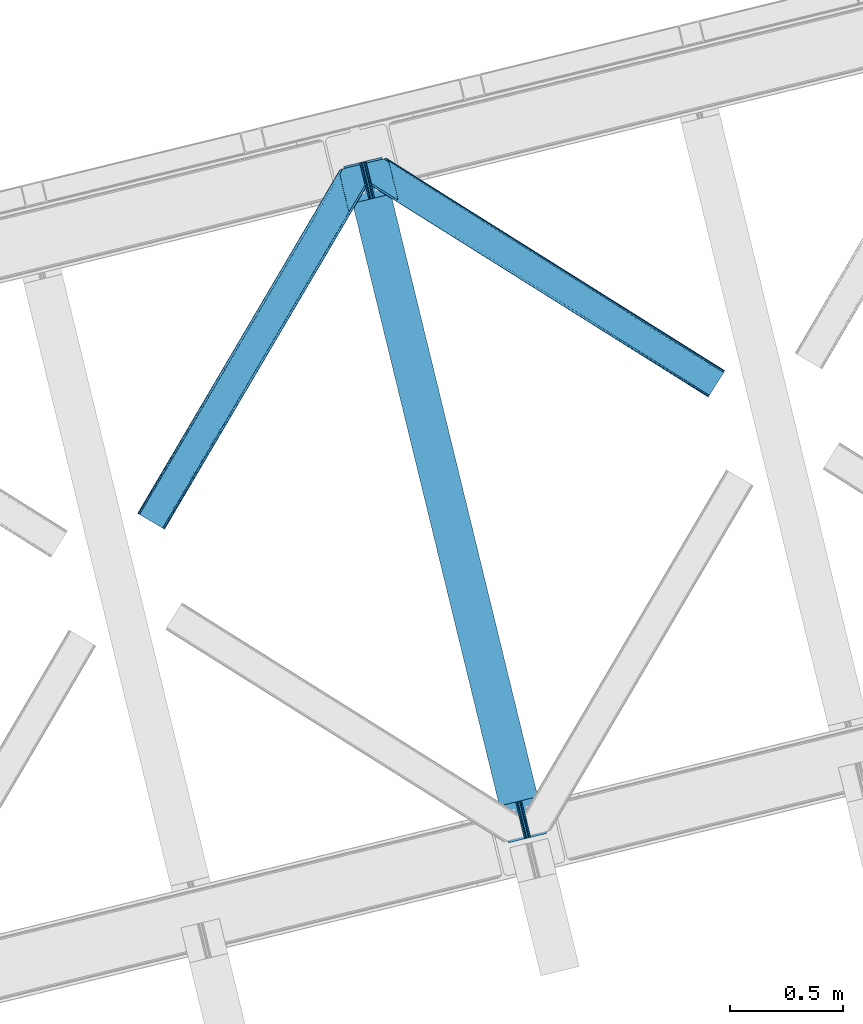
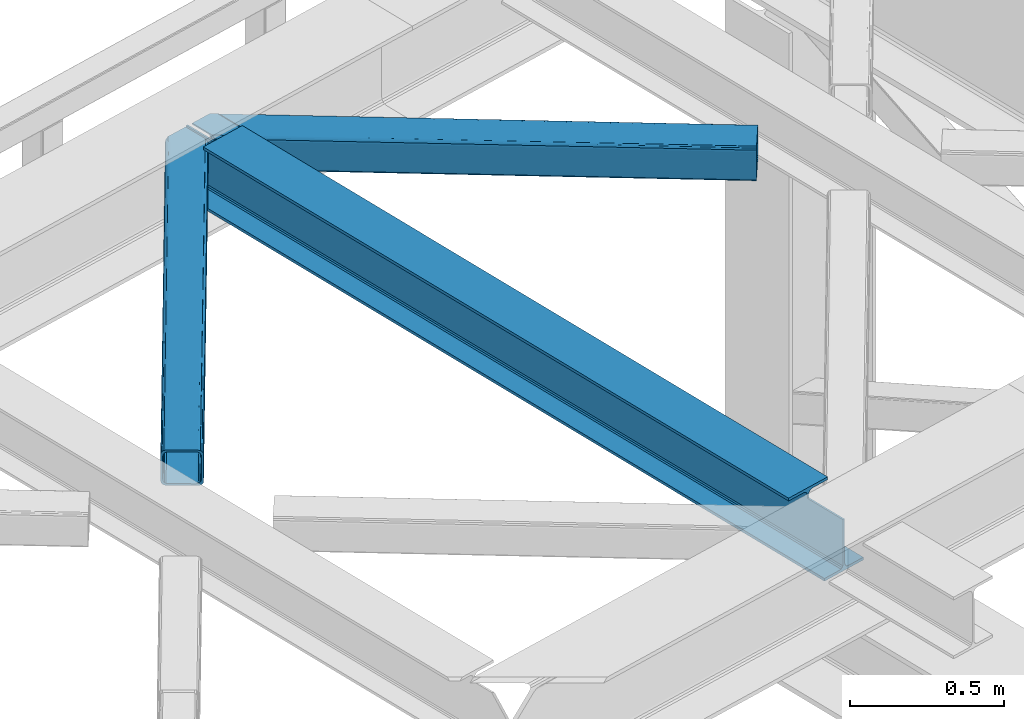
# One storey, part 36 of 92: 2 members, 1 beam.
"""IFC4 building model written with IfcOpenShell, lengths in millimetres."""

from ifc_helpers import new_model, entity, si_unit, converted_unit, derived_unit, direction, frame, origin, place, context, subcontext, project, spatial, triangles, polygons, material, type_object, element, save


model = new_model("IFC4")

# Units and contexts
model_context = context("Model", 3, precision=0.01, world=origin(), true_north=direction((6.12303176911189e-17, 1.0)))
plan_context = context("Plan", 3, precision=0.01, world=origin(), true_north=direction((6.12303176911189e-17, 1.0)))
body_context = subcontext(model_context, "Body", "Model", "MODEL_VIEW")
ifc_project = project(units=[si_unit("LENGTHUNIT", "METRE", prefix="MILLI"), si_unit("AREAUNIT", "SQUARE_METRE"), si_unit("VOLUMEUNIT", "CUBIC_METRE"), converted_unit("PLANEANGLEUNIT", "DEGREE", entity("IfcRatioMeasure", 0.0174532925199433), si_unit("PLANEANGLEUNIT", "RADIAN"), dimensions=[0, 0, 0, 0, 0, 0, 0]), si_unit("MASSUNIT", "GRAM", prefix="KILO"), derived_unit("MASSDENSITYUNIT", [(si_unit("MASSUNIT", "GRAM", prefix="KILO"), 1), (si_unit("LENGTHUNIT", "METRE"), -3)]), derived_unit("MOMENTOFINERTIAUNIT", [(si_unit("LENGTHUNIT", "METRE"), 4)]), si_unit("TIMEUNIT", "SECOND"), si_unit("FREQUENCYUNIT", "HERTZ"), si_unit("THERMODYNAMICTEMPERATUREUNIT", "DEGREE_CELSIUS"), derived_unit("THERMALTRANSMITTANCEUNIT", [(si_unit("MASSUNIT", "GRAM", prefix="KILO"), 1), (si_unit("THERMODYNAMICTEMPERATUREUNIT", "KELVIN"), -1), (si_unit("TIMEUNIT", "SECOND"), -3)]), derived_unit("VOLUMETRICFLOWRATEUNIT", [(si_unit("LENGTHUNIT", "METRE"), 3), (si_unit("TIMEUNIT", "SECOND"), -1)]), derived_unit("MASSFLOWRATEUNIT", [(si_unit("MASSUNIT", "GRAM", prefix="KILO"), 1), (si_unit("TIMEUNIT", "SECOND"), -1)]), derived_unit("ROTATIONALFREQUENCYUNIT", [(si_unit("TIMEUNIT", "SECOND"), -1)]), si_unit("ELECTRICCURRENTUNIT", "AMPERE"), si_unit("ELECTRICVOLTAGEUNIT", "VOLT"), si_unit("POWERUNIT", "WATT"), si_unit("FORCEUNIT", "NEWTON", prefix="KILO"), si_unit("ILLUMINANCEUNIT", "LUX"), si_unit("LUMINOUSFLUXUNIT", "LUMEN"), si_unit("LUMINOUSINTENSITYUNIT", "CANDELA"), derived_unit("USERDEFINED", [(si_unit("MASSUNIT", "GRAM", prefix="KILO"), -1), (si_unit("LENGTHUNIT", "METRE"), -2), (si_unit("TIMEUNIT", "SECOND"), 3), (si_unit("LUMINOUSFLUXUNIT", "LUMEN"), 1)]), derived_unit("LINEARVELOCITYUNIT", [(si_unit("LENGTHUNIT", "METRE"), 1), (si_unit("TIMEUNIT", "SECOND"), -1)]), si_unit("PRESSUREUNIT", "PASCAL"), derived_unit("USERDEFINED", [(si_unit("LENGTHUNIT", "METRE"), -2), (si_unit("MASSUNIT", "GRAM", prefix="KILO"), 1), (si_unit("TIMEUNIT", "SECOND"), -2)]), derived_unit("LINEARFORCEUNIT", [(si_unit("MASSUNIT", "GRAM", prefix="KILO"), 1), (si_unit("LENGTHUNIT", "METRE"), 1), (si_unit("TIMEUNIT", "SECOND"), -2), (si_unit("LENGTHUNIT", "METRE"), -1)]), derived_unit("PLANARFORCEUNIT", [(si_unit("MASSUNIT", "GRAM", prefix="KILO"), 1), (si_unit("LENGTHUNIT", "METRE"), 1), (si_unit("TIMEUNIT", "SECOND"), -2), (si_unit("LENGTHUNIT", "METRE"), -2)])], contexts=[model_context, plan_context])

# Site, building, storey
site_placement = place(None, origin())
site = spatial("IfcSite", under=ifc_project, at=site_placement, CompositionType="ELEMENT")
building_placement = place(site_placement, origin())
building = spatial("IfcBuilding", under=site, at=building_placement, CompositionType="ELEMENT")
storey_placement = place(building_placement, frame((0.0, 0.0, 15900.0)))
storey = spatial("IfcBuildingStorey", under=building, at=storey_placement, Name="05", CompositionType="ELEMENT", Elevation=15900.0)

# Beam
ifc_material = material(Name="Metal painted (White)")
beam_type = type_object("IfcBeamType", PredefinedType="BEAM")
beam_placement = place(storey_placement, frame((-52349.25, 5026.02, 3441.0)))
element("IfcBeam", 1, at=beam_placement, inside=storey, type_object=beam_type, material=ifc_material, ObjectType="Steel Beam", PredefinedType="BEAM", context=body_context, shape_type="Tessellation", body=[
    polygons([(900.98534618944, 41.4445662733081, 11.000000000004), (900.98534618944, 41.4445662733092, 2.16573425859679e-12), (170.021610174761, 3040.13999372697, 2.16573425859679e-12), (170.021610174761, 3040.13999372697, 11.000000000004), (834.919806235814, 25.3403919499656, 11.000000000004), (103.956070221144, 3024.03581940362, 11.000000000004), (828.971056214522, 23.8903211957396, 12.2179274798217), (98.0073201998427, 3022.5857486494, 12.2179274798217), (823.927949458413, 22.6610105689194, 15.6862915010192), (92.964213443734, 3021.35643802258, 15.6862915010192), (820.558253255237, 21.8396114687119, 20.8770650821657), (89.5945172405581, 3020.53503892237, 20.8770650821657), (819.374973305552, 21.5511744621195, 27.0000000000047), (88.4112372908723, 3020.24660191578, 27.0000000000047), (81.6103728838888, 3018.58881926485, 27.0000000000047), (81.6103728838801, 3018.58881926485, 203.000000000006), (88.4112372908723, 3020.24660191578, 203.000000000006), (0.0, 2998.69542745366, 2.16573425859679e-12), (0.0, 2998.69542745366, 10.9999999999997), (66.0655399536259, 3014.799601777, 11.000000000004), (72.0142899749184, 3016.24967253123, 12.2179274798217), (77.0573967310183, 3017.47898315805, 15.6862915010192), (80.4270929342029, 3018.30038225826, 20.8770650821657), (819.374973305552, 21.5511744621195, 203.000000000006), (812.574108898559, 19.8933918111876, 203.000000000006), (812.574108898559, 19.8933918111886, 27.0000000000047), (811.390828948873, 19.6049548045974, 20.8770650821657), (808.021132745698, 18.7835557043887, 15.6862915010192), (802.978025989589, 17.5542450775696, 12.2179274798217), (797.029275968305, 16.1041743233425, 11.000000000004), (730.963736014671, 0.0, 10.9999999999997), (730.963736014671, 0.0, 2.16573425859679e-12), (779.675212882749, 184.415062601691, 203.069791966819), (128.020401343504, 2857.75452019162, 203.000000000006), (128.24328213265, 2856.8401777572, 203.617301946336), (128.256196377169, 2856.7871977843, 217.000003693143), (779.530009633824, 185.010597404071, 217.000003676718), (779.530880241722, 185.007025963191, 204.00000679514), (772.964911718311, 182.385463974442, 203.006342981529), (772.742064056773, 183.299815969774, 203.617301946336), (772.729149812254, 183.352795942667, 217.000003693143), (121.455336555608, 2855.1293963229, 217.000003676718), (121.454465947701, 2855.13296776377, 204.00000679514), (121.310166358655, 2855.72494066435, 203.076120467494), (121.219536936511, 2856.09673754069, 203.000000000006), (780.71349435786, 185.298194377514, 223.122939328039), (784.082490766539, 186.122464201393, 228.313710402595), (789.125126170563, 187.353708426697, 231.782072735464), (795.073705041266, 188.80448128138, 232.999999602236), (861.13915590679, 204.909021065315, 232.999999283132), (861.137682570352, 204.915065042187, 243.999994005812), (691.116301666431, 163.469558245298, 243.999994827032), (691.117775002869, 163.463514268423, 233.000000104353), (757.183225868392, 179.568054052358, 232.999999785253), (763.132130996722, 181.017488520583, 231.782072861012), (768.175695503853, 182.244921343717, 228.313710479427), (771.546082413593, 183.063487001147, 223.12293937232), (120.271851831563, 2854.84179934945, 223.122939328039), (116.902855422884, 2854.01752952557, 228.313710402595), (111.860220018877, 2852.78628530027, 231.782072735464), (105.911641148165, 2851.33551244559, 232.999999602236), (39.8461902826419, 2835.23097266165, 232.999999283128), (39.8476636190794, 2835.22492868478, 243.999994005812), (209.869044523001, 2876.67043548167, 243.999994827032), (209.867571186554, 2876.67647945854, 233.000000104357), (143.802120321031, 2860.57193967461, 232.999999785253), (137.853215192701, 2859.12250520639, 231.782072861012), (132.80965068557, 2857.89507238325, 228.313710479427), (129.439263775838, 2857.07650672582, 223.12293937232)], [[[1, 2, 3, 4]], [[5, 1, 4, 6]], [[7, 5, 6, 8]], [[9, 7, 8, 10]], [[11, 9, 10, 12]], [[13, 11, 12, 14]], [[15, 16, 17, 14, 12, 10, 8, 6, 4, 3, 18, 19, 20, 21, 22, 23]], [[13, 24, 25, 26, 27, 28, 29, 30, 31, 32, 2, 1, 5, 7, 9, 11]], [[2, 32, 18, 3]], [[32, 31, 19, 18]], [[31, 30, 20, 19]], [[27, 26, 15, 23]], [[28, 27, 23, 22]], [[29, 28, 22, 21]], [[30, 29, 21, 20]], [[33, 24, 13, 14, 17, 34, 35, 36, 37, 38]], [[25, 39, 40, 41, 42, 43, 44, 16, 15, 26]], [[39, 25, 24, 33]], [[45, 34, 17, 16]], [[41, 40, 38, 37, 46, 47, 48, 49, 50, 51, 52, 53, 54, 55, 56, 57]], [[42, 58, 59, 60, 61, 62, 63, 64, 65, 66, 67, 68, 69, 36, 35, 43]], [[46, 37, 36, 69]], [[47, 46, 69, 68]], [[48, 47, 68, 67]], [[49, 48, 67, 66]], [[50, 49, 66, 65]], [[51, 50, 65, 64]], [[52, 51, 64, 63]], [[53, 52, 63, 62]], [[54, 53, 62, 61]], [[55, 54, 61, 60]], [[56, 55, 60, 59]], [[57, 56, 59, 58]], [[41, 57, 58, 42]]], closed=False),
])

# Members
member_type_1 = type_object("IfcMemberType", PredefinedType="BRACE")
member_1_placement = place(storey_placement, frame((-52247.53, 7001.53, 3511.0)))
element("IfcMember", 2, at=member_1_placement, inside=storey, type_object=member_type_1, ObjectType="Steel Horizontal Brace", PredefinedType="BRACE", context=body_context, shape_type="Tessellation", body=[
    triangles([(207.717553710936, 841.064360046387, 0.0), (172.040661621089, 987.427519226075, 0.0), (1579.91751708985, 103.755294799805, 0.0), (1524.09766845703, 14.8223510742191, 0.0), (1589.22392578125, 118.577645874024, 17.5000946044929), (1588.51234130859, 117.449226379395, 10.8028289794929), (166.547973632813, 1009.96393432617, 10.8028289794929), (166.092187499999, 1011.82079772949, 17.5000946044929), (1586.49851074219, 114.236050415039, 5.12526855468968), (167.836267089842, 1004.67646636963, 5.12526855468968), (1583.48009033203, 109.42762298584, 1.33247680664135), (169.766381835936, 996.762414550782, 1.33247680664135), (1520.53974609375, 9.15002288818323, 1.33247680664135), (202.587634277341, 836.379180908203, 1.33247680664135), (208.508203124999, 837.822697448731, 0.155804443362285), (1517.52132568359, 4.34159545898456, 5.12526855468968), (194.895080566406, 834.504295349121, 5.12526855468968), (1515.50284423828, 1.12841949462927, 10.8028289794929), (189.755859375, 833.250883483887, 10.8028289794929), (1514.79591064453, 0.0, 17.5000946044929), (187.946667480464, 832.811375427246, 17.5000946044929), (204.378222656247, 836.815782165528, 12.1260040283232), (208.508203124999, 837.822697448731, 9.69243164062573), (199.648278808592, 835.662945556641, 17.9802978515654), (198.420446777345, 835.364126586915, 19.4999725341804), (187.946667480464, 832.811375427246, 19.4999725341804), (25.3054321289019, 934.895260620117, 19.4999725341804), (22.6823364257798, 945.669602966309, 19.4999725341804), (1514.79591064453, 0.0, 122.500662231447), (25.3054321289019, 934.895260620117, 122.500662231447), (1527.81837158203, 20.7510589599606, 6.99957275390625), (205.340954589839, 850.821903991699, 6.99957275390625), (207.559423828126, 841.724784851074, 8.88434143066479), (1524.26044921875, 15.0787307739256, 8.3320495605476), (1521.24202880859, 10.2703033447269, 12.1260040283232), (1519.22354736328, 7.05712738037073, 17.8035644531265), (1518.51661376953, 5.92870788574237, 24.4996673583992), (22.9288330078125, 944.65280456543, 24.4996673583992), (174.417260742186, 977.669975280762, 6.99957275390625), (1576.19681396485, 97.8265869140623, 6.99957275390625), (168.966430664063, 1000.03372650147, 17.8803039550803), (170.212866210939, 994.918922424316, 12.1260040283232), (172.142980957033, 987.004870605469, 8.3320495605476), (168.831555175777, 1000.58485565186, 18.5000335693367), (166.092187499999, 1011.82079772949, 18.5000335693367), (1518.51661376953, 5.92870788574237, 115.501089477541), (22.9288330078125, 944.65280456543, 115.501089477541), (1527.81837158203, 20.7510589599606, 133.000021362306), (1524.26044921875, 15.0787307739256, 131.667544555665), (19.2592895507769, 959.711187744141, 131.667544555665), (16.9803588867144, 969.046664428711, 133.000021362306), (1521.24202880859, 10.2703033447269, 127.87475280762), (21.1847534179688, 951.797135925293, 127.87475280762), (1519.22354736328, 7.05712738037073, 122.196029663086), (22.4776977539077, 946.50966796875, 122.196029663086), (168.515295410158, 1000.87902374268, 18.7407165527366), (165.808483886714, 1012.00160064697, 18.736065673831), (168.171130371091, 1001.19702758789, 19.0000030517585), (165.487573242186, 1012.20275115967, 19.0000030517585), (167.822314453122, 1001.51503143311, 19.2592895507842), (165.166662597658, 1012.4033203125, 19.2639404296897), (167.506054687496, 1001.80919952393, 19.4999725341804), (164.878308105464, 1012.58412322998, 19.4999725341804), (78.2928955078096, 1057.80520019531, 19.4999725341804), (88.7666748046831, 1060.35795135498, 19.4999725341804), (24.8542968749971, 936.752124023437, 129.197927856447), (23.5660034179673, 942.040173339844, 134.874325561526), (22.1195800781206, 947.964811706544, 137.999716186525), (0.0, 1038.71973724365, 137.999716186525), (0.0, 1038.71973724365, 133.000021362306), (1589.22392578125, 118.577645874024, 122.500662231447), (88.7666748046831, 1060.35795135498, 122.500662231447), (1584.79163818359, 111.520518493652, 17.8035644531265), (1585.49857177735, 112.648356628418, 24.4996673583992), (79.2788818359331, 1058.04588317871, 24.4996673583992), (1579.75938720703, 103.498915100097, 8.3320495605476), (1582.77780761719, 108.307342529297, 12.1260040283232), (64.6425659179658, 1054.47807769775, 131.667544555665), (55.5687011718765, 1052.26600341797, 133.000021362306), (76.0604736328096, 1057.26104736328, 137.999716186525), (81.8182617187485, 1058.66503143311, 134.874325561526), (72.3351196289077, 1056.35296325684, 127.87475280762), (77.474340820314, 1057.60579376221, 122.196029663086), (86.962133789064, 1059.91786193848, 129.197927856447), (79.2788818359331, 1058.04588317871, 115.501089477541), (1576.19681396485, 97.8265869140623, 133.000021362306), (1585.49857177735, 112.648356628418, 115.501089477541), (1584.79163818359, 111.520518493652, 122.196029663086), (1582.77780761719, 108.307342529297, 127.87475280762), (1579.75938720703, 103.498915100097, 131.667544555665), (1588.51234130859, 117.449226379395, 129.197927856447), (1586.49851074219, 114.236050415039, 134.874325561526), (1583.48009033203, 109.42762298584, 138.667117309571), (1579.91751708985, 103.755294799805, 139.999594116212), (1524.09766845703, 14.8223510742191, 139.999594116212), (1520.53974609375, 9.15002288818323, 138.667117309571), (1517.52132568359, 4.34159545898456, 134.874325561526), (1515.50284423828, 1.12841949462927, 129.197927856447), (98.1893554687485, 1043.37177886963, 137.999716186525), (139.386840820313, 874.360583496094, 137.999716186525), (137.842749023439, 884.922148132325, 139.999594116212), (139.824023437497, 876.794155883789, 138.999655151369), (140.051916503908, 875.6302734375, 138.667117309571), (139.805419921875, 874.273379516601, 138.076455688479), (139.917041015622, 874.907643127442, 138.353182983399), (98.7056030273452, 1042.87529754639, 138.076455688479), (99.5985717773438, 1040.78589019775, 138.634561157229), (99.1985961914033, 1041.72362365723, 138.383413696291), (100.184582519527, 1039.41271820068, 138.999655151369), (102.165856933592, 1031.28472595215, 139.999594116212), (140.033312988278, 875.544232177735, 138.629910278323)], [[1, 2, 3], [3, 4, 1], [5, 6, 7], [7, 8, 5], [6, 9, 10], [10, 7, 6], [9, 11, 12], [12, 10, 9], [11, 3, 2], [2, 12, 11], [13, 14, 15], [15, 4, 13], [15, 1, 4], [13, 16, 14], [17, 14, 16], [16, 18, 17], [19, 17, 18], [18, 20, 19], [21, 19, 20], [22, 23, 14], [22, 14, 17], [17, 19, 24], [23, 15, 14], [24, 22, 17], [19, 21, 25], [26, 25, 21], [19, 25, 24], [27, 28, 25], [25, 26, 27], [26, 29, 30], [20, 26, 21], [26, 20, 29], [26, 30, 27], [31, 32, 33], [34, 33, 23], [23, 35, 34], [23, 22, 35], [36, 35, 22], [37, 36, 24], [24, 25, 37], [37, 25, 38], [28, 38, 25], [22, 24, 36], [33, 34, 31], [39, 32, 40], [31, 40, 32], [41, 7, 10], [10, 42, 41], [12, 42, 10], [42, 12, 43], [7, 44, 8], [45, 8, 44], [7, 41, 44], [43, 12, 2], [33, 32, 1], [1, 39, 2], [39, 1, 32], [15, 33, 1], [39, 43, 2], [23, 33, 15], [46, 37, 38], [38, 47, 46], [48, 49, 50], [50, 51, 48], [49, 52, 53], [53, 50, 49], [52, 54, 55], [55, 53, 52], [54, 46, 47], [47, 55, 54], [45, 44, 56], [56, 57, 45], [57, 56, 58], [58, 59, 57], [59, 58, 60], [60, 61, 59], [61, 60, 62], [62, 63, 61], [64, 65, 63], [63, 62, 64], [47, 27, 30], [66, 55, 30], [55, 66, 67], [55, 47, 30], [38, 27, 47], [28, 27, 38], [53, 55, 67], [68, 51, 50], [51, 68, 69], [69, 70, 51], [50, 53, 68], [68, 53, 67], [5, 45, 71], [8, 45, 5], [45, 72, 71], [72, 45, 57], [72, 57, 59], [59, 61, 72], [63, 72, 61], [72, 63, 65], [73, 41, 42], [74, 75, 62], [62, 73, 74], [56, 73, 58], [56, 44, 73], [73, 60, 58], [73, 62, 60], [44, 41, 73], [75, 64, 62], [40, 76, 39], [43, 39, 76], [76, 77, 43], [42, 43, 77], [42, 77, 73], [78, 79, 80], [81, 82, 80], [78, 80, 82], [83, 81, 84], [79, 69, 80], [79, 70, 69], [83, 82, 81], [72, 85, 83], [85, 72, 65], [75, 65, 64], [65, 75, 85], [72, 83, 84], [51, 79, 86], [79, 51, 70], [86, 48, 51], [74, 87, 85], [85, 75, 74], [87, 88, 85], [83, 85, 88], [88, 89, 83], [82, 83, 89], [89, 90, 82], [78, 82, 90], [90, 86, 78], [79, 78, 86], [91, 89, 88], [87, 5, 71], [91, 88, 71], [91, 92, 89], [88, 87, 71], [89, 92, 93], [86, 94, 95], [94, 90, 93], [90, 94, 86], [90, 89, 93], [6, 77, 9], [74, 5, 87], [5, 73, 6], [73, 5, 74], [6, 73, 77], [3, 40, 4], [11, 9, 77], [77, 76, 11], [76, 40, 3], [3, 11, 76], [52, 96, 97], [95, 48, 86], [95, 49, 48], [49, 95, 96], [52, 49, 96], [46, 29, 20], [98, 54, 52], [97, 98, 52], [54, 98, 29], [46, 54, 29], [13, 35, 16], [4, 40, 31], [31, 34, 4], [34, 35, 13], [13, 4, 34], [18, 16, 35], [20, 37, 46], [36, 20, 18], [20, 36, 37], [36, 18, 35], [80, 68, 99], [80, 69, 68], [100, 99, 68], [95, 101, 102], [102, 96, 95], [102, 103, 96], [97, 104, 100], [100, 67, 97], [100, 68, 67], [96, 105, 104], [96, 103, 105], [104, 97, 96], [29, 98, 30], [66, 30, 98], [98, 97, 66], [67, 66, 97], [92, 81, 106], [106, 93, 92], [107, 93, 108], [106, 108, 93], [81, 80, 99], [107, 94, 93], [107, 109, 94], [109, 110, 94], [92, 91, 84], [84, 81, 92], [91, 71, 72], [72, 84, 91], [110, 101, 94], [95, 94, 101], [111, 102, 109], [109, 107, 111], [107, 108, 104], [108, 106, 104], [110, 109, 101], [102, 101, 109]]),
])
member_type_2 = type_object("IfcMemberType", PredefinedType="BRACE")
member_2_placement = place(storey_placement, frame((-53262.93, 6415.95, 3511.0)))
element("IfcMember", 3, at=member_2_placement, inside=storey, type_object=member_type_2, ObjectType="Steel Horizontal Brace", PredefinedType="BRACE", context=body_context, shape_type="Tessellation", body=[
    triangles([(105.565649414064, 8.87852783203107, 0.0), (15.0781494140683, 62.148532104492, 0.0), (892.847827148442, 1346.13992614746, 0.0), (857.166284179693, 1492.50250396729, 0.0), (854.892004394533, 1501.83739929199, 1.33247680664135), (9.31105957031832, 65.5459991455082, 1.33247680664135), (852.961889648439, 1509.75145111084, 5.12526855468968), (4.4183349609375, 68.4266372680668, 5.12526855468968), (851.673596191409, 1515.03950042725, 10.8028289794929), (1.14876708984957, 70.3509384155277, 10.8028289794929), (851.222460937504, 1516.89636383057, 17.5000946044929), (0.0, 71.027059936524, 17.5000946044929), (893.633825683595, 1342.89826354981, 0.155804443362285), (111.332739257814, 5.48106079101581, 1.33247680664135), (899.559045410162, 1344.34178009033, 1.33247680664135), (912.390820312503, 1347.46949615479, 10.8028289794929), (914.195361328129, 1347.90958557129, 17.5000946044929), (120.643798828125, 0.0, 17.5000946044929), (119.495031738283, 0.675540161132631, 10.8028289794929), (907.251599121097, 1346.21666564941, 5.12526855468968), (116.225463867188, 2.60042266845721, 5.12526855468968), (902.493750000001, 1345.05743408203, 17.9802978515654), (893.633825683595, 1342.89826354981, 9.69243164062573), (897.768457031256, 1343.90459747315, 12.1260040283232), (903.721582031256, 1345.35683441162, 19.4999725341804), (914.195361328129, 1347.90958557129, 19.4999725341804), (1011.61732177735, 1513.38669433594, 19.4999725341804), (1008.98957519532, 1524.16103668213, 19.4999725341804), (1011.61732177735, 1513.38669433594, 122.500662231447), (120.643798828125, 0.0, 122.500662231447), (114.61160888672, 3.5515274047857, 24.4996673583992), (1009.23607177735, 1523.14423828125, 24.4996673583992), (113.462841796878, 4.22706756591833, 17.8035644531265), (110.193273925783, 6.15195007324201, 12.1260040283232), (105.300549316409, 9.03200683593786, 8.3320495605476), (99.52880859375, 12.4294738769531, 6.99957275390625), (892.685046386723, 1346.79976959229, 8.88434143066479), (890.466577148443, 1355.89747009277, 6.99957275390625), (21.1103393554731, 58.5975860595709, 6.99957275390625), (859.547534179692, 1482.74496002197, 6.99957275390625), (853.961828613283, 1505.66042175293, 18.5000335693367), (851.222460937504, 1516.89636383057, 18.5000335693367), (854.096704101568, 1505.10929260254, 17.8803039550803), (855.343139648438, 1499.99390716553, 12.1260040283232), (857.273254394531, 1492.07985534668, 8.3320495605476), (1009.23607177735, 1523.14423828125, 115.501089477541), (114.61160888672, 3.5515274047857, 115.501089477541), (1008.78493652344, 1525.00110168457, 122.196029663086), (113.462841796878, 4.22706756591833, 122.196029663086), (1007.49664306641, 1530.28915100098, 127.87475280762), (110.193273925783, 6.15195007324201, 127.87475280762), (1005.56652832031, 1538.20320281982, 131.667544555665), (105.300549316409, 9.03200683593786, 131.667544555665), (1003.29224853516, 1547.53809814453, 133.000021362306), (99.52880859375, 12.4294738769531, 133.000021362306), (851.952648925784, 1518.13291625977, 19.4999725341804), (854.575744628906, 1507.35857391357, 19.4999725341804), (851.780566406254, 1517.84049224854, 19.2639404296897), (854.426916503908, 1506.95045928955, 19.2592895507842), (851.585229492193, 1517.51434936523, 19.0000030517585), (854.268786621098, 1506.50920715332, 19.0000030517585), (851.394543457034, 1517.1887878418, 18.736065673831), (854.110656738281, 1506.06853637695, 18.7407165527366), (908.014343261719, 1598.12687072754, 19.4999725341804), (897.540563964845, 1595.57411956787, 19.4999725341804), (1011.16618652344, 1515.24355773926, 129.197927856447), (1009.8732421875, 1520.53160705566, 134.874325561526), (1008.43146972657, 1526.45624542236, 137.999716186525), (986.307238769536, 1617.21175231934, 137.999716186525), (986.307238769536, 1617.21175231934, 133.000021362306), (897.540563964845, 1595.57411956787, 122.500662231447), (0.0, 71.027059936524, 122.500662231447), (7.18095703125437, 66.7999923706057, 17.8035644531265), (10.4505249023496, 64.8751098632811, 12.1260040283232), (6.03218994141207, 67.4755325317383, 24.4996673583992), (907.023706054693, 1597.88560638428, 24.4996673583992), (15.3432495117231, 61.9944717407225, 8.3320495605476), (908.832897949222, 1598.32569580078, 122.196029663086), (899.345104980472, 1596.01362762451, 129.197927856447), (904.484326171878, 1597.26645812988, 134.874325561526), (930.73388671875, 1603.66548614502, 133.000021362306), (910.246765136719, 1598.67044219971, 137.999716186525), (921.664672851563, 1601.45341186523, 131.667544555665), (913.972119140628, 1599.57852630615, 127.87475280762), (907.023706054693, 1597.88560638428, 115.501089477541), (21.1103393554731, 58.5975860595709, 133.000021362306), (6.03218994141207, 67.4755325317383, 115.501089477541), (15.3432495117231, 61.9944717407225, 131.667544555665), (10.4505249023496, 64.8751098632811, 127.87475280762), (7.18095703125437, 66.7999923706057, 122.196029663086), (119.495031738283, 0.675540161132631, 129.197927856447), (116.225463867188, 2.60042266845721, 134.874325561526), (111.332739257814, 5.48106079101581, 138.667117309571), (105.565649414064, 8.87852783203107, 139.999594116212), (15.0781494140683, 62.148532104492, 139.999594116212), (9.31105957031832, 65.5459991455082, 138.667117309571), (4.4183349609375, 68.4266372680668, 134.874325561526), (1.14876708984957, 70.3509384155277, 129.197927856447), (896.991760253906, 1576.15611877441, 137.999716186525), (938.18924560547, 1407.14434204102, 137.999716186525), (899.024194335943, 1563.59525756836, 139.999594116212), (897.042919921878, 1571.72266845703, 138.999655151369), (896.796423339845, 1573.13711700439, 138.639212036134), (896.926647949222, 1575.15443572998, 138.211331176761), (896.861535644537, 1574.14170684815, 138.427597045898), (937.473010253911, 1407.08562469482, 138.29272155762), (937.077685546879, 1408.09486541748, 138.646188354494), (936.682360839848, 1409.10410614014, 138.999655151369), (934.701086425783, 1417.23267974854, 139.999594116212)], [[1, 2, 3], [4, 3, 2], [5, 4, 6], [2, 6, 4], [7, 5, 8], [6, 8, 5], [9, 7, 10], [8, 10, 7], [11, 9, 12], [10, 12, 9], [1, 3, 13], [13, 14, 1], [13, 15, 14], [16, 17, 18], [18, 19, 16], [20, 16, 19], [19, 21, 20], [15, 20, 21], [21, 14, 15], [20, 22, 16], [23, 24, 15], [23, 15, 13], [15, 24, 20], [16, 25, 17], [20, 24, 22], [16, 22, 25], [26, 17, 25], [26, 25, 27], [28, 27, 25], [27, 29, 26], [30, 26, 29], [26, 18, 17], [30, 18, 26], [31, 32, 25], [25, 33, 31], [25, 22, 33], [32, 28, 25], [33, 22, 24], [34, 24, 23], [23, 35, 34], [36, 35, 37], [37, 38, 36], [23, 37, 35], [24, 34, 33], [39, 36, 38], [38, 40, 39], [9, 11, 41], [11, 42, 41], [43, 9, 41], [43, 7, 9], [44, 7, 43], [5, 44, 45], [44, 5, 7], [4, 5, 45], [45, 40, 4], [37, 23, 13], [37, 3, 38], [3, 40, 38], [40, 3, 4], [37, 13, 3], [46, 32, 31], [31, 47, 46], [48, 46, 49], [47, 49, 46], [50, 48, 51], [49, 51, 48], [52, 50, 53], [51, 53, 50], [54, 52, 55], [53, 55, 52], [56, 57, 58], [59, 58, 57], [58, 59, 60], [61, 60, 59], [60, 61, 62], [63, 62, 61], [62, 63, 42], [41, 42, 63], [57, 56, 64], [65, 64, 56], [66, 48, 67], [46, 29, 27], [27, 32, 46], [32, 27, 28], [48, 29, 46], [66, 29, 48], [50, 68, 67], [52, 68, 50], [67, 48, 50], [52, 54, 68], [54, 69, 68], [70, 69, 54], [71, 60, 62], [58, 60, 71], [71, 56, 58], [56, 71, 65], [42, 12, 72], [12, 42, 11], [71, 42, 72], [42, 71, 62], [73, 74, 44], [75, 73, 43], [43, 41, 75], [43, 57, 75], [64, 76, 57], [75, 57, 76], [44, 43, 73], [45, 44, 74], [74, 77, 45], [40, 45, 77], [77, 39, 40], [78, 79, 80], [81, 82, 69], [69, 70, 81], [81, 83, 82], [84, 82, 83], [80, 82, 84], [78, 71, 79], [85, 71, 78], [80, 84, 78], [65, 76, 64], [85, 65, 71], [76, 65, 85], [86, 54, 55], [54, 86, 81], [70, 54, 81], [76, 85, 87], [87, 75, 76], [83, 81, 86], [86, 88, 83], [84, 83, 88], [88, 89, 84], [78, 84, 89], [89, 90, 78], [85, 78, 90], [90, 87, 85], [91, 51, 49], [47, 18, 30], [91, 49, 30], [91, 92, 51], [49, 47, 30], [51, 92, 93], [55, 94, 95], [94, 53, 93], [53, 94, 55], [53, 51, 93], [19, 34, 21], [31, 18, 47], [18, 33, 19], [33, 18, 31], [19, 33, 34], [1, 36, 2], [14, 21, 34], [34, 35, 14], [35, 36, 1], [1, 14, 35], [89, 96, 97], [95, 86, 55], [95, 88, 86], [88, 95, 96], [89, 88, 96], [87, 72, 12], [98, 90, 89], [97, 98, 89], [90, 98, 72], [87, 90, 72], [6, 74, 8], [2, 36, 39], [39, 77, 2], [77, 74, 6], [6, 2, 77], [10, 8, 74], [12, 75, 87], [73, 12, 10], [12, 73, 75], [73, 10, 74], [99, 68, 82], [99, 100, 68], [68, 69, 82], [96, 95, 101], [101, 102, 96], [97, 96, 103], [104, 97, 105], [104, 99, 97], [97, 103, 105], [82, 80, 99], [97, 99, 80], [102, 103, 96], [79, 71, 98], [72, 98, 71], [80, 79, 97], [98, 97, 79], [92, 67, 100], [100, 93, 92], [67, 68, 100], [106, 107, 93], [94, 93, 107], [107, 108, 94], [108, 109, 94], [66, 67, 92], [92, 91, 66], [29, 66, 91], [91, 30, 29], [95, 94, 109], [109, 101, 95], [107, 103, 102], [105, 103, 107], [106, 104, 105], [100, 99, 104], [107, 106, 105], [102, 108, 107], [102, 101, 109], [109, 108, 102]]),
])

save(model, "model.ifc")
